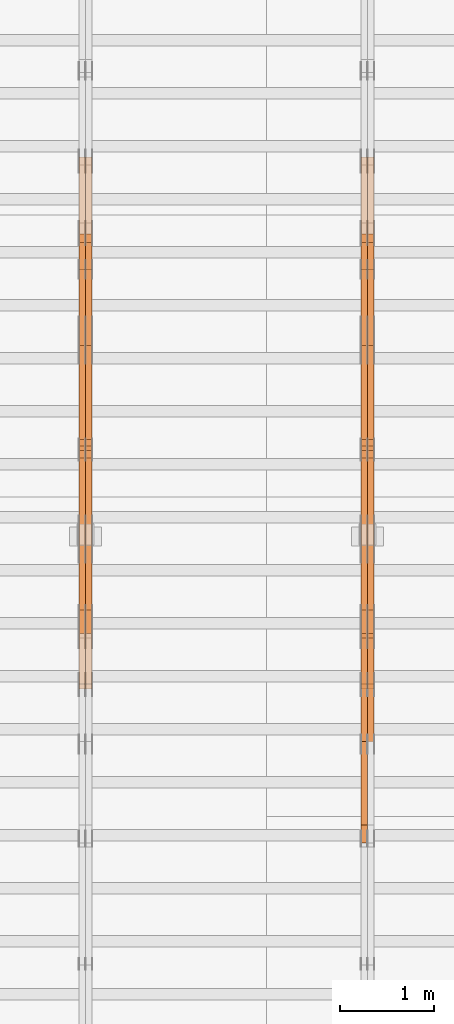
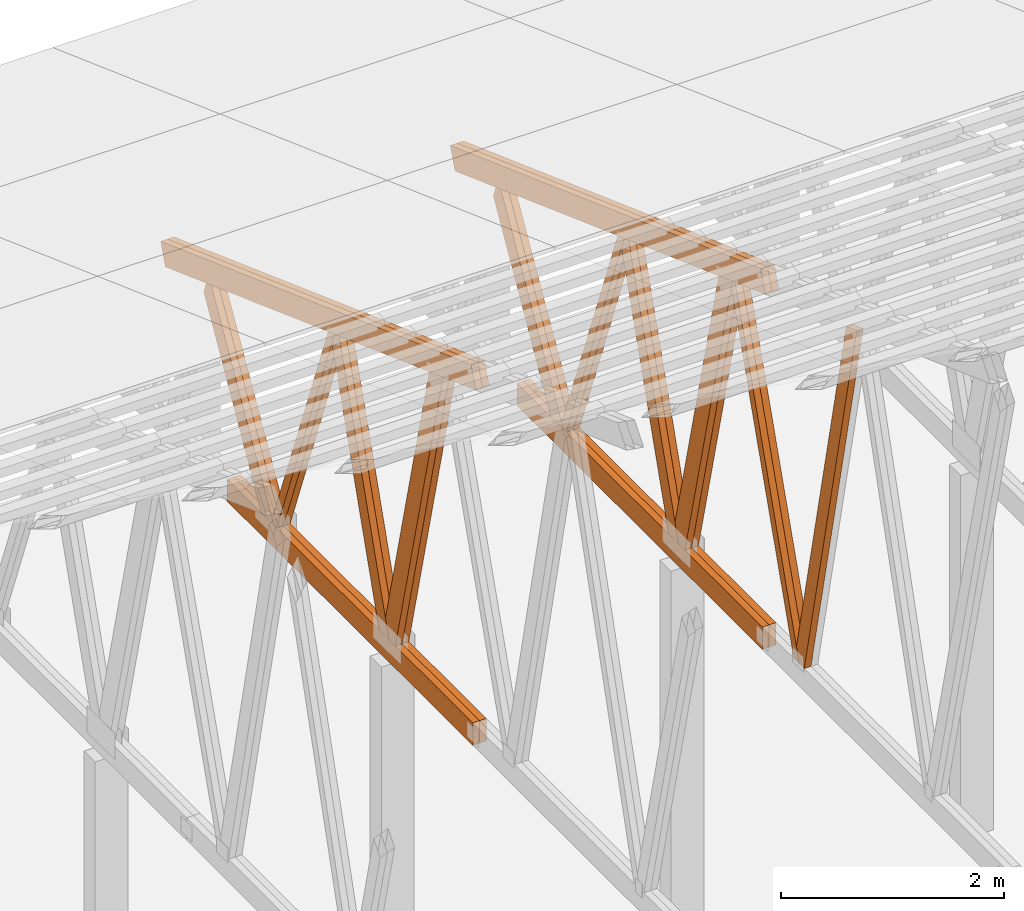
# One storey, part 34 of 189: 27 proxies.
"""IFC2X3 building model written with IfcOpenShell, lengths in millimetres."""

from ifc_helpers import new_model, entity, si_unit, converted_unit, derived_unit, direction, frame, origin, origin_2d_with_axis, place, context, subcontext, project, spatial, polyline, rectangle, outline, extrude, source, transform, mapped, material, type_object, type_shapes, element, save


model = new_model("IFC2X3")

# Units and contexts
model_context = context("Model", 3, precision=0.01, world=origin(), true_north=direction((6.12303176911189e-17, 1.0)))
body_context = subcontext(model_context, "Body", "Model", "MODEL_VIEW")
ifc_project = project(units=[si_unit("LENGTHUNIT", "METRE", prefix="MILLI"), si_unit("AREAUNIT", "SQUARE_METRE"), si_unit("VOLUMEUNIT", "CUBIC_METRE"), converted_unit("PLANEANGLEUNIT", "DEGREE", entity("IfcRatioMeasure", 0.0174532925199433), si_unit("PLANEANGLEUNIT", "RADIAN"), dimensions=[0, 0, 0, 0, 0, 0, 0]), si_unit("MASSUNIT", "GRAM", prefix="KILO"), derived_unit("MASSDENSITYUNIT", [(si_unit("MASSUNIT", "GRAM", prefix="KILO"), 1), (si_unit("LENGTHUNIT", "METRE"), -3)]), si_unit("TIMEUNIT", "SECOND"), si_unit("FREQUENCYUNIT", "HERTZ"), si_unit("THERMODYNAMICTEMPERATUREUNIT", "DEGREE_CELSIUS"), derived_unit("THERMALTRANSMITTANCEUNIT", [(si_unit("MASSUNIT", "GRAM", prefix="KILO"), 1), (si_unit("THERMODYNAMICTEMPERATUREUNIT", "KELVIN"), -1), (si_unit("TIMEUNIT", "SECOND"), -3)]), derived_unit("VOLUMETRICFLOWRATEUNIT", [(si_unit("LENGTHUNIT", "METRE"), 3), (si_unit("TIMEUNIT", "SECOND"), -1)]), si_unit("ELECTRICCURRENTUNIT", "AMPERE"), si_unit("ELECTRICVOLTAGEUNIT", "VOLT"), si_unit("POWERUNIT", "WATT"), si_unit("FORCEUNIT", "NEWTON"), si_unit("ILLUMINANCEUNIT", "LUX"), si_unit("LUMINOUSFLUXUNIT", "LUMEN"), si_unit("LUMINOUSINTENSITYUNIT", "CANDELA"), derived_unit("USERDEFINED", [(si_unit("MASSUNIT", "GRAM", prefix="KILO"), -1), (si_unit("LENGTHUNIT", "METRE"), -2), (si_unit("TIMEUNIT", "SECOND"), 3), (si_unit("LUMINOUSFLUXUNIT", "LUMEN"), 1)]), derived_unit("LINEARVELOCITYUNIT", [(si_unit("LENGTHUNIT", "METRE"), 1), (si_unit("TIMEUNIT", "SECOND"), -1)]), si_unit("PRESSUREUNIT", "PASCAL"), derived_unit("USERDEFINED", [(si_unit("LENGTHUNIT", "METRE"), -2), (si_unit("MASSUNIT", "GRAM", prefix="KILO"), 1), (si_unit("TIMEUNIT", "SECOND"), -2)])], contexts=[model_context])

# Site, building, storey
site_placement = place(None, origin())
site = spatial("IfcSite", under=ifc_project, at=site_placement, CompositionType="ELEMENT")
building_placement = place(site_placement, origin())
building = spatial("IfcBuilding", under=site, at=building_placement, CompositionType="ELEMENT")
storey_placement = place(building_placement, origin())
storey = spatial("IfcBuildingStorey", under=building, at=storey_placement, Name="Default", CompositionType="ELEMENT", Elevation=0.0)

# Proxies
ifc_material_1 = material(Name="IfcSurfaceStyle #67908")
building_element_proxy_type_1 = type_object("IfcBuildingElementProxyType", Name="T1-W3 67906", PredefinedType="NOTDEFINED", material=ifc_material_1)
shared_shape_1 = source(origin(), body_context, "Body", "SweptSolid", [
    extrude(outline(polyline([(-2517.58938959787, -85.0001104675026), (1625.445846867, -85.0001104675027), (1768.20563426494, 0.000209440697654673), (1749.48871563991, 85.0000057471538), (-2625.55080717397, 85.0000057471538), (-2517.58938959787, -85.0001104675026)])), frame((1768.2056683344, 85.0000547211315, 0.0), z_axis=(0.0, 0.0, 1.0), x_axis=(-1.0, 0.0, 0.0)), (0.0, 0.0, 1.0), 69.9999999999997),
])
type_shapes(building_element_proxy_type_1, [shared_shape_1])
proxy_1_placement = place(building_placement, frame((12230.0, 18415.3042863408, 226.720947016584), z_axis=(-1.0, 0.0, 0.0), x_axis=(0.0, -0.215047682154604, 0.976603550269982)))
element("IfcBuildingElementProxy", 1, at=proxy_1_placement, inside=storey, type_object=building_element_proxy_type_1, material=ifc_material_1, Name="T1-W3", context=body_context, shape_type="MappedRepresentation", body=[
    mapped(shared_shape_1, transform((0.0, 0.0, 0.0), scale=1.0)),
])
ifc_material_2 = material(Name="IfcSurfaceStyle #67710")
building_element_proxy_type_2 = type_object("IfcBuildingElementProxyType", Name="T1-W7 67708", PredefinedType="NOTDEFINED", material=ifc_material_2)
shared_shape_2 = source(origin(), body_context, "Body", "SweptSolid", [
    extrude(outline(polyline([(-2189.6662270939, -47.5000140805343), (1475.30081553583, -47.5000140805343), (1473.93388518462, 0.00042343352179337), (1398.58463533215, 47.4998023637734), (-2158.15310895869, 47.4998023637734), (-2189.6662270939, -47.5000140805343)])), frame((1475.30081553583, 47.5004895824757, 0.0), z_axis=(0.0, 0.0, 1.0), x_axis=(-1.0, 0.0, 0.0)), (0.0, 0.0, 1.0), 69.9999999999998),
])
type_shapes(building_element_proxy_type_2, [shared_shape_2])
proxy_2_placement = place(building_placement, frame((12300.0, 19742.3819153401, 3693.66743808885), z_axis=(-1.0, 0.0, 0.0), x_axis=(0.0, -0.314845237923104, -0.949143021971475)))
element("IfcBuildingElementProxy", 2, at=proxy_2_placement, inside=storey, type_object=building_element_proxy_type_2, material=ifc_material_2, Name="T1-W7", context=body_context, shape_type="MappedRepresentation", body=[
    mapped(shared_shape_2, transform((0.0, 0.0, 0.0), scale=1.0)),
])
ifc_material_3 = material(Name="IfcSurfaceStyle #67644")
building_element_proxy_type_3 = type_object("IfcBuildingElementProxyType", Name="T1-W7 67642", PredefinedType="NOTDEFINED", material=ifc_material_3)
shared_shape_3 = source(origin(), body_context, "Body", "SweptSolid", [
    extrude(outline(polyline([(-2189.6662270939, -47.5000140805343), (1475.30081553583, -47.5000140805343), (1473.93388518462, 0.00042343352179337), (1398.58463533215, 47.4998023637734), (-2158.15310895869, 47.4998023637734), (-2189.6662270939, -47.5000140805343)])), frame((1475.30081553583, 47.5004895824757, 0.0), z_axis=(0.0, 0.0, 1.0), x_axis=(-1.0, 0.0, 0.0)), (0.0, 0.0, 1.0), 69.9999999999998),
])
type_shapes(building_element_proxy_type_3, [shared_shape_3])
proxy_3_placement = place(building_placement, frame((12230.0, 19742.3819153401, 3693.66743808885), z_axis=(-1.0, 0.0, 0.0), x_axis=(0.0, -0.314845237923104, -0.949143021971475)))
element("IfcBuildingElementProxy", 3, at=proxy_3_placement, inside=storey, type_object=building_element_proxy_type_3, material=ifc_material_3, Name="T1-W7", context=body_context, shape_type="MappedRepresentation", body=[
    mapped(shared_shape_3, transform((0.0, 0.0, 0.0), scale=1.0)),
])
ifc_material_4 = material(Name="IfcSurfaceStyle #67446")
building_element_proxy_type_4 = type_object("IfcBuildingElementProxyType", Name="T1-W1 67444", PredefinedType="NOTDEFINED", material=ifc_material_4)
shared_shape_4 = source(origin(), body_context, "Body", "SweptSolid", [
    extrude(outline(polyline([(-1996.99427801396, -109.999889649051), (1271.09905152223, -109.999889649051), (1448.88120817726, -0.000113190727324008), (1421.70802776002, 109.999946244415), (-2144.69400944554, 109.999946244415), (-1996.99427801396, -109.999889649051)])), frame((1448.88120817726, 110.000265670598, 0.0), z_axis=(0.0, 0.0, 1.0), x_axis=(-1.0, 0.0, 0.0)), (0.0, 0.0, 1.0), 69.9999999999998),
])
type_shapes(building_element_proxy_type_4, [shared_shape_4])
proxy_4_placement = place(building_placement, frame((12300.0, 20558.6774904859, 218.61972674968), z_axis=(-1.0, 0.0, 0.0), x_axis=(0.0, -0.239819839925979, 0.970817410421691)))
element("IfcBuildingElementProxy", 4, at=proxy_4_placement, inside=storey, type_object=building_element_proxy_type_4, material=ifc_material_4, Name="T1-W1", context=body_context, shape_type="MappedRepresentation", body=[
    mapped(shared_shape_4, transform((0.0, 0.0, 0.0), scale=1.0)),
])
ifc_material_5 = material(Name="IfcSurfaceStyle #67380")
building_element_proxy_type_5 = type_object("IfcBuildingElementProxyType", Name="T1-W1 67378", PredefinedType="NOTDEFINED", material=ifc_material_5)
shared_shape_5 = source(origin(), body_context, "Body", "SweptSolid", [
    extrude(outline(polyline([(-1996.99427801396, -109.999889649051), (1271.09905152223, -109.999889649051), (1448.88120817726, -0.000113190727324008), (1421.70802776002, 109.999946244415), (-2144.69400944554, 109.999946244415), (-1996.99427801396, -109.999889649051)])), frame((1448.88120817726, 110.000265670598, 0.0), z_axis=(0.0, 0.0, 1.0), x_axis=(-1.0, 0.0, 0.0)), (0.0, 0.0, 1.0), 69.9999999999998),
])
type_shapes(building_element_proxy_type_5, [shared_shape_5])
proxy_5_placement = place(building_placement, frame((12230.0, 20558.6774904859, 218.61972674968), z_axis=(-1.0, 0.0, 0.0), x_axis=(0.0, -0.239819839925979, 0.970817410421691)))
element("IfcBuildingElementProxy", 5, at=proxy_5_placement, inside=storey, type_object=building_element_proxy_type_5, material=ifc_material_5, Name="T1-W1", context=body_context, shape_type="MappedRepresentation", body=[
    mapped(shared_shape_5, transform((0.0, 0.0, 0.0), scale=1.0)),
])
ifc_material_6 = material(Name="IfcSurfaceStyle #67182")
building_element_proxy_type_6 = type_object("IfcBuildingElementProxyType", Name="T1-W4 67180", PredefinedType="NOTDEFINED", material=ifc_material_6)
shared_shape_6 = source(origin(), body_context, "Body", "SweptSolid", [
    extrude(outline(polyline([(-1742.90513395849, -84.9997422414737), (1181.3544167489, -84.9997422414737), (1178.19398821251, -0.000208932978430543), (1071.44989130457, 84.999846707963), (-1688.09316230749, 84.999846707963), (-1742.90513395849, -84.9997422414737)])), frame((1181.35452116422, 84.999886337523, 0.0), z_axis=(0.0, 0.0, 1.0), x_axis=(-1.0, 0.0, 0.0)), (0.0, 0.0, 1.0), 69.9999999999998),
])
type_shapes(building_element_proxy_type_6, [shared_shape_6])
proxy_6_placement = place(building_placement, frame((12300.0, 21724.6281517871, 2976.00232464744), z_axis=(-1.0, 0.0, 0.0), x_axis=(0.0, -0.306868406216495, -0.951751953644514)))
element("IfcBuildingElementProxy", 6, at=proxy_6_placement, inside=storey, type_object=building_element_proxy_type_6, material=ifc_material_6, Name="T1-W4", context=body_context, shape_type="MappedRepresentation", body=[
    mapped(shared_shape_6, transform((0.0, 0.0, 0.0), scale=1.0)),
])
ifc_material_7 = material(Name="IfcSurfaceStyle #67116")
building_element_proxy_type_7 = type_object("IfcBuildingElementProxyType", Name="T1-W4 67114", PredefinedType="NOTDEFINED", material=ifc_material_7)
shared_shape_7 = source(origin(), body_context, "Body", "SweptSolid", [
    extrude(outline(polyline([(-1742.90513395849, -84.9997422414737), (1181.3544167489, -84.9997422414737), (1178.19398821251, -0.000208932978430543), (1071.44989130457, 84.999846707963), (-1688.09316230749, 84.999846707963), (-1742.90513395849, -84.9997422414737)])), frame((1181.35452116422, 84.999886337523, 0.0), z_axis=(0.0, 0.0, 1.0), x_axis=(-1.0, 0.0, 0.0)), (0.0, 0.0, 1.0), 69.9999999999998),
])
type_shapes(building_element_proxy_type_7, [shared_shape_7])
proxy_7_placement = place(building_placement, frame((12230.0, 21724.6281517871, 2976.00232464744), z_axis=(-1.0, 0.0, 0.0), x_axis=(0.0, -0.306868406216495, -0.951751953644514)))
element("IfcBuildingElementProxy", 7, at=proxy_7_placement, inside=storey, type_object=building_element_proxy_type_7, material=ifc_material_7, Name="T1-W4", context=body_context, shape_type="MappedRepresentation", body=[
    mapped(shared_shape_7, transform((0.0, 0.0, 0.0), scale=1.0)),
])
ifc_material_8 = material(Name="IfcSurfaceStyle #66918")
building_element_proxy_type_8 = type_object("IfcBuildingElementProxyType", Name="T1-W8 66916", PredefinedType="NOTDEFINED", material=ifc_material_8)
shared_shape_8 = source(origin(), body_context, "Body", "SweptSolid", [
    extrude(outline(polyline([(-1700.10906247918, -47.4998559987011), (1140.60243146647, -47.4998559987011), (1179.56122089033, 0.000120838919977206), (1161.65086478184, 47.4997955792411), (-1781.70545465947, 47.4997955792411), (-1700.10906247918, -47.4998559987011)])), frame((1179.56128464708, 47.5000634692093, 0.0), z_axis=(0.0, 0.0, 1.0), x_axis=(-1.0, 0.0, 0.0)), (0.0, 0.0, 1.0), 69.9999999999998),
])
type_shapes(building_element_proxy_type_8, [shared_shape_8])
proxy_8_placement = place(building_placement, frame((12300.0, 22687.5385403115, 228.241249073207), z_axis=(-1.0, 0.0, 0.0), x_axis=(0.0, -0.352814979177604, 0.93569310698963)))
element("IfcBuildingElementProxy", 8, at=proxy_8_placement, inside=storey, type_object=building_element_proxy_type_8, material=ifc_material_8, Name="T1-W8", context=body_context, shape_type="MappedRepresentation", body=[
    mapped(shared_shape_8, transform((0.0, 0.0, 0.0), scale=1.0)),
])
ifc_material_9 = material(Name="IfcSurfaceStyle #66852")
building_element_proxy_type_9 = type_object("IfcBuildingElementProxyType", Name="T1-W8 66850", PredefinedType="NOTDEFINED", material=ifc_material_9)
shared_shape_9 = source(origin(), body_context, "Body", "SweptSolid", [
    extrude(outline(polyline([(-1700.10906247918, -47.4998559987011), (1140.60243146647, -47.4998559987011), (1179.56122089033, 0.000120838919977206), (1161.65086478184, 47.4997955792411), (-1781.70545465947, 47.4997955792411), (-1700.10906247918, -47.4998559987011)])), frame((1179.56128464708, 47.5000634692093, 0.0), z_axis=(0.0, 0.0, 1.0), x_axis=(-1.0, 0.0, 0.0)), (0.0, 0.0, 1.0), 69.9999999999998),
])
type_shapes(building_element_proxy_type_9, [shared_shape_9])
proxy_9_placement = place(building_placement, frame((12230.0, 22687.5385403115, 228.241249073207), z_axis=(-1.0, 0.0, 0.0), x_axis=(0.0, -0.352814979177604, 0.93569310698963)))
element("IfcBuildingElementProxy", 9, at=proxy_9_placement, inside=storey, type_object=building_element_proxy_type_9, material=ifc_material_9, Name="T1-W8", context=body_context, shape_type="MappedRepresentation", body=[
    mapped(shared_shape_9, transform((0.0, 0.0, 0.0), scale=1.0)),
])
ifc_material_10 = material(Name="IfcSurfaceStyle #66654")
building_element_proxy_type_10 = type_object("IfcBuildingElementProxyType", Name="T1-W2 66652", PredefinedType="NOTDEFINED", material=ifc_material_10)
shared_shape_10 = source(origin(), body_context, "Body", "SweptSolid", [
    extrude(outline(polyline([(-1361.89144606429, -97.5000598486876), (887.613245225805, -97.5000598486876), (904.774262962339, 0.000302345139042259), (818.892339969004, 97.4999086761182), (-1249.38840209286, 97.4999086761182), (-1361.89144606429, -97.5000598486876)])), frame((904.774262962339, 97.5000966763391, 0.0), z_axis=(0.0, 0.0, 1.0), x_axis=(-1.0, 0.0, 0.0)), (0.0, 0.0, 1.0), 69.9999999999999),
])
type_shapes(building_element_proxy_type_10, [shared_shape_10])
proxy_10_placement = place(building_placement, frame((12300.0, 24033.6159173732, 2110.89189244614), z_axis=(-1.0, 0.0, 0.0), x_axis=(0.0, -0.5, -0.866025403784439)))
element("IfcBuildingElementProxy", 10, at=proxy_10_placement, inside=storey, type_object=building_element_proxy_type_10, material=ifc_material_10, Name="T1-W2", context=body_context, shape_type="MappedRepresentation", body=[
    mapped(shared_shape_10, transform((0.0, 0.0, 0.0), scale=1.0)),
])
ifc_material_11 = material(Name="IfcSurfaceStyle #66588")
building_element_proxy_type_11 = type_object("IfcBuildingElementProxyType", Name="T1-W2 66586", PredefinedType="NOTDEFINED", material=ifc_material_11)
shared_shape_11 = source(origin(), body_context, "Body", "SweptSolid", [
    extrude(outline(polyline([(-1361.89144606429, -97.5000598486876), (887.613245225805, -97.5000598486876), (904.774262962339, 0.000302345139042259), (818.892339969004, 97.4999086761182), (-1249.38840209286, 97.4999086761182), (-1361.89144606429, -97.5000598486876)])), frame((904.774262962339, 97.5000966763391, 0.0), z_axis=(0.0, 0.0, 1.0), x_axis=(-1.0, 0.0, 0.0)), (0.0, 0.0, 1.0), 69.9999999999999),
])
type_shapes(building_element_proxy_type_11, [shared_shape_11])
proxy_11_placement = place(building_placement, frame((12230.0, 24033.6159173732, 2110.89189244614), z_axis=(-1.0, 0.0, 0.0), x_axis=(0.0, -0.5, -0.866025403784439)))
element("IfcBuildingElementProxy", 11, at=proxy_11_placement, inside=storey, type_object=building_element_proxy_type_11, material=ifc_material_11, Name="T1-W2", context=body_context, shape_type="MappedRepresentation", body=[
    mapped(shared_shape_11, transform((0.0, 0.0, 0.0), scale=1.0)),
])
ifc_material_12 = material(Name="IfcSurfaceStyle #64578")
building_element_proxy_type_12 = type_object("IfcBuildingElementProxyType", Name="T1-B4 64576", PredefinedType="NOTDEFINED", material=ifc_material_12)
shared_shape_12 = source(origin(), body_context, "Body", "SweptSolid", [
    extrude(rectangle(XDim=4408.2412109375, YDim=245.000000000001, at=origin_2d_with_axis()), frame((2204.12060546875, 122.5, 0.0), z_axis=(0.0, 0.0, 1.0), x_axis=(-1.0, 0.0, 0.0)), (0.0, 0.0, 1.0), 69.9999999999997),
])
type_shapes(building_element_proxy_type_12, [shared_shape_12])
proxy_12_placement = place(building_placement, frame((12300.0, 19161.7587890625, 245.0), z_axis=(-1.0, 0.0, 0.0), x_axis=(0.0, 1.0, 0.0)))
element("IfcBuildingElementProxy", 12, at=proxy_12_placement, inside=storey, type_object=building_element_proxy_type_12, material=ifc_material_12, Name="T1-B4", context=body_context, shape_type="MappedRepresentation", body=[
    mapped(shared_shape_12, transform((0.0, 0.0, 0.0), scale=1.0)),
])
ifc_material_13 = material(Name="IfcSurfaceStyle #64521")
building_element_proxy_type_13 = type_object("IfcBuildingElementProxyType", Name="T1-B4 64519", PredefinedType="NOTDEFINED", material=ifc_material_13)
shared_shape_13 = source(origin(), body_context, "Body", "SweptSolid", [
    extrude(rectangle(XDim=4408.2412109375, YDim=245.000000000001, at=origin_2d_with_axis()), frame((2204.12060546875, 122.5, 0.0), z_axis=(0.0, 0.0, 1.0), x_axis=(-1.0, 0.0, 0.0)), (0.0, 0.0, 1.0), 69.9999999999997),
])
type_shapes(building_element_proxy_type_13, [shared_shape_13])
proxy_13_placement = place(building_placement, frame((12230.0, 19161.7587890625, 245.0), z_axis=(-1.0, 0.0, 0.0), x_axis=(0.0, 1.0, 0.0)))
element("IfcBuildingElementProxy", 13, at=proxy_13_placement, inside=storey, type_object=building_element_proxy_type_13, material=ifc_material_13, Name="T1-B4", context=body_context, shape_type="MappedRepresentation", body=[
    mapped(shared_shape_13, transform((0.0, 0.0, 0.0), scale=1.0)),
])
ifc_material_14 = material(Name="IfcSurfaceStyle #63534")
building_element_proxy_type_14 = type_object("IfcBuildingElementProxyType", Name="T1-T1 63532", PredefinedType="NOTDEFINED", material=ifc_material_14)
shared_shape_14 = source(origin(), body_context, "Body", "SweptSolid", [
    extrude(outline(polyline([(-2964.99982426074, -122.499947708046), (2964.99981923522, -122.499947708046), (2964.99984513599, 122.499947708046), (-2964.99984011047, 122.499947708046), (-2964.99982426074, -122.499947708046)])), frame((2964.99984513599, 122.499998966405, 0.0), z_axis=(0.0, 0.0, 1.0), x_axis=(-1.0, 0.0, 0.0)), (0.0, 0.0, 1.0), 69.9999999999996),
])
type_shapes(building_element_proxy_type_14, [shared_shape_14])
proxy_14_placement = place(building_placement, frame((12300.0, 24681.3398262186, 1893.12531804384), z_axis=(-1.0, 0.0, 0.0), x_axis=(0.0, -0.939692620785908, 0.342020143325669)))
element("IfcBuildingElementProxy", 14, at=proxy_14_placement, inside=storey, type_object=building_element_proxy_type_14, material=ifc_material_14, Name="T1-T1", context=body_context, shape_type="MappedRepresentation", body=[
    mapped(shared_shape_14, transform((0.0, 0.0, 0.0), scale=1.0)),
])
ifc_material_15 = material(Name="IfcSurfaceStyle #63477")
building_element_proxy_type_15 = type_object("IfcBuildingElementProxyType", Name="T1-T1 63475", PredefinedType="NOTDEFINED", material=ifc_material_15)
shared_shape_15 = source(origin(), body_context, "Body", "SweptSolid", [
    extrude(outline(polyline([(-2964.99982426074, -122.499947708046), (2964.99981923522, -122.499947708046), (2964.99984513599, 122.499947708046), (-2964.99984011047, 122.499947708046), (-2964.99982426074, -122.499947708046)])), frame((2964.99984513599, 122.499998966405, 0.0), z_axis=(0.0, 0.0, 1.0), x_axis=(-1.0, 0.0, 0.0)), (0.0, 0.0, 1.0), 69.9999999999996),
])
type_shapes(building_element_proxy_type_15, [shared_shape_15])
proxy_15_placement = place(building_placement, frame((12230.0, 24681.3398262186, 1893.12531804384), z_axis=(-1.0, 0.0, 0.0), x_axis=(0.0, -0.939692620785908, 0.342020143325669)))
element("IfcBuildingElementProxy", 15, at=proxy_15_placement, inside=storey, type_object=building_element_proxy_type_15, material=ifc_material_15, Name="T1-T1", context=body_context, shape_type="MappedRepresentation", body=[
    mapped(shared_shape_15, transform((0.0, 0.0, 0.0), scale=1.0)),
])
ifc_material_16 = material(Name="IfcSurfaceStyle #51656")
building_element_proxy_type_16 = type_object("IfcBuildingElementProxyType", Name="T1-W1 51654", PredefinedType="NOTDEFINED", material=ifc_material_16)
shared_shape_16 = source(origin(), body_context, "Body", "SweptSolid", [
    extrude(outline(polyline([(-1996.99427801396, -109.999889649051), (1271.09905152223, -109.999889649051), (1448.88120817726, -0.000113190727324008), (1421.70802776002, 109.999946244415), (-2144.69400944554, 109.999946244415), (-1996.99427801396, -109.999889649051)])), frame((1448.88120817726, 110.000265670598, 0.0), z_axis=(0.0, 0.0, 1.0), x_axis=(-1.0, 0.0, 0.0)), (0.0, 0.0, 1.0), 69.9999999999998),
])
type_shapes(building_element_proxy_type_16, [shared_shape_16])
proxy_16_placement = place(building_placement, frame((9300.0, 20558.6774904859, 218.61972674968), z_axis=(-1.0, 0.0, 0.0), x_axis=(0.0, -0.239819839925979, 0.970817410421691)))
element("IfcBuildingElementProxy", 16, at=proxy_16_placement, inside=storey, type_object=building_element_proxy_type_16, material=ifc_material_16, Name="T1-W1", context=body_context, shape_type="MappedRepresentation", body=[
    mapped(shared_shape_16, transform((0.0, 0.0, 0.0), scale=1.0)),
])
ifc_material_17 = material(Name="IfcSurfaceStyle #51590")
building_element_proxy_type_17 = type_object("IfcBuildingElementProxyType", Name="T1-W1 51588", PredefinedType="NOTDEFINED", material=ifc_material_17)
shared_shape_17 = source(origin(), body_context, "Body", "SweptSolid", [
    extrude(outline(polyline([(-1996.99427801396, -109.999889649051), (1271.09905152223, -109.999889649051), (1448.88120817726, -0.000113190727324008), (1421.70802776002, 109.999946244415), (-2144.69400944554, 109.999946244415), (-1996.99427801396, -109.999889649051)])), frame((1448.88120817726, 110.000265670598, 0.0), z_axis=(0.0, 0.0, 1.0), x_axis=(-1.0, 0.0, 0.0)), (0.0, 0.0, 1.0), 69.9999999999998),
])
type_shapes(building_element_proxy_type_17, [shared_shape_17])
proxy_17_placement = place(building_placement, frame((9230.0, 20558.6774904859, 218.61972674968), z_axis=(-1.0, 0.0, 0.0), x_axis=(0.0, -0.239819839925979, 0.970817410421691)))
element("IfcBuildingElementProxy", 17, at=proxy_17_placement, inside=storey, type_object=building_element_proxy_type_17, material=ifc_material_17, Name="T1-W1", context=body_context, shape_type="MappedRepresentation", body=[
    mapped(shared_shape_17, transform((0.0, 0.0, 0.0), scale=1.0)),
])
ifc_material_18 = material(Name="IfcSurfaceStyle #51392")
building_element_proxy_type_18 = type_object("IfcBuildingElementProxyType", Name="T1-W4 51390", PredefinedType="NOTDEFINED", material=ifc_material_18)
shared_shape_18 = source(origin(), body_context, "Body", "SweptSolid", [
    extrude(outline(polyline([(-1742.90513395849, -84.9997422414737), (1181.3544167489, -84.9997422414737), (1178.19398821251, -0.000208932978430543), (1071.44989130457, 84.999846707963), (-1688.09316230749, 84.999846707963), (-1742.90513395849, -84.9997422414737)])), frame((1181.35452116422, 84.999886337523, 0.0), z_axis=(0.0, 0.0, 1.0), x_axis=(-1.0, 0.0, 0.0)), (0.0, 0.0, 1.0), 69.9999999999998),
])
type_shapes(building_element_proxy_type_18, [shared_shape_18])
proxy_18_placement = place(building_placement, frame((9300.0, 21724.6281517871, 2976.00232464744), z_axis=(-1.0, 0.0, 0.0), x_axis=(0.0, -0.306868406216495, -0.951751953644514)))
element("IfcBuildingElementProxy", 18, at=proxy_18_placement, inside=storey, type_object=building_element_proxy_type_18, material=ifc_material_18, Name="T1-W4", context=body_context, shape_type="MappedRepresentation", body=[
    mapped(shared_shape_18, transform((0.0, 0.0, 0.0), scale=1.0)),
])
ifc_material_19 = material(Name="IfcSurfaceStyle #51326")
building_element_proxy_type_19 = type_object("IfcBuildingElementProxyType", Name="T1-W4 51324", PredefinedType="NOTDEFINED", material=ifc_material_19)
shared_shape_19 = source(origin(), body_context, "Body", "SweptSolid", [
    extrude(outline(polyline([(-1742.90513395849, -84.9997422414737), (1181.3544167489, -84.9997422414737), (1178.19398821251, -0.000208932978430543), (1071.44989130457, 84.999846707963), (-1688.09316230749, 84.999846707963), (-1742.90513395849, -84.9997422414737)])), frame((1181.35452116422, 84.999886337523, 0.0), z_axis=(0.0, 0.0, 1.0), x_axis=(-1.0, 0.0, 0.0)), (0.0, 0.0, 1.0), 69.9999999999998),
])
type_shapes(building_element_proxy_type_19, [shared_shape_19])
proxy_19_placement = place(building_placement, frame((9230.0, 21724.6281517871, 2976.00232464744), z_axis=(-1.0, 0.0, 0.0), x_axis=(0.0, -0.306868406216495, -0.951751953644514)))
element("IfcBuildingElementProxy", 19, at=proxy_19_placement, inside=storey, type_object=building_element_proxy_type_19, material=ifc_material_19, Name="T1-W4", context=body_context, shape_type="MappedRepresentation", body=[
    mapped(shared_shape_19, transform((0.0, 0.0, 0.0), scale=1.0)),
])
ifc_material_20 = material(Name="IfcSurfaceStyle #51128")
building_element_proxy_type_20 = type_object("IfcBuildingElementProxyType", Name="T1-W8 51126", PredefinedType="NOTDEFINED", material=ifc_material_20)
shared_shape_20 = source(origin(), body_context, "Body", "SweptSolid", [
    extrude(outline(polyline([(-1700.10906247918, -47.4998559987011), (1140.60243146647, -47.4998559987011), (1179.56122089033, 0.000120838919977206), (1161.65086478184, 47.4997955792411), (-1781.70545465947, 47.4997955792411), (-1700.10906247918, -47.4998559987011)])), frame((1179.56128464708, 47.5000634692093, 0.0), z_axis=(0.0, 0.0, 1.0), x_axis=(-1.0, 0.0, 0.0)), (0.0, 0.0, 1.0), 69.9999999999998),
])
type_shapes(building_element_proxy_type_20, [shared_shape_20])
proxy_20_placement = place(building_placement, frame((9300.0, 22687.5385403115, 228.241249073207), z_axis=(-1.0, 0.0, 0.0), x_axis=(0.0, -0.352814979177604, 0.93569310698963)))
element("IfcBuildingElementProxy", 20, at=proxy_20_placement, inside=storey, type_object=building_element_proxy_type_20, material=ifc_material_20, Name="T1-W8", context=body_context, shape_type="MappedRepresentation", body=[
    mapped(shared_shape_20, transform((0.0, 0.0, 0.0), scale=1.0)),
])
ifc_material_21 = material(Name="IfcSurfaceStyle #51062")
building_element_proxy_type_21 = type_object("IfcBuildingElementProxyType", Name="T1-W8 51060", PredefinedType="NOTDEFINED", material=ifc_material_21)
shared_shape_21 = source(origin(), body_context, "Body", "SweptSolid", [
    extrude(outline(polyline([(-1700.10906247918, -47.4998559987011), (1140.60243146647, -47.4998559987011), (1179.56122089033, 0.000120838919977206), (1161.65086478184, 47.4997955792411), (-1781.70545465947, 47.4997955792411), (-1700.10906247918, -47.4998559987011)])), frame((1179.56128464708, 47.5000634692093, 0.0), z_axis=(0.0, 0.0, 1.0), x_axis=(-1.0, 0.0, 0.0)), (0.0, 0.0, 1.0), 69.9999999999998),
])
type_shapes(building_element_proxy_type_21, [shared_shape_21])
proxy_21_placement = place(building_placement, frame((9230.0, 22687.5385403115, 228.241249073207), z_axis=(-1.0, 0.0, 0.0), x_axis=(0.0, -0.352814979177604, 0.93569310698963)))
element("IfcBuildingElementProxy", 21, at=proxy_21_placement, inside=storey, type_object=building_element_proxy_type_21, material=ifc_material_21, Name="T1-W8", context=body_context, shape_type="MappedRepresentation", body=[
    mapped(shared_shape_21, transform((0.0, 0.0, 0.0), scale=1.0)),
])
ifc_material_22 = material(Name="IfcSurfaceStyle #50864")
building_element_proxy_type_22 = type_object("IfcBuildingElementProxyType", Name="T1-W2 50862", PredefinedType="NOTDEFINED", material=ifc_material_22)
shared_shape_22 = source(origin(), body_context, "Body", "SweptSolid", [
    extrude(outline(polyline([(-1361.89144606429, -97.5000598486876), (887.613245225805, -97.5000598486876), (904.774262962339, 0.000302345139042259), (818.892339969004, 97.4999086761182), (-1249.38840209286, 97.4999086761182), (-1361.89144606429, -97.5000598486876)])), frame((904.774262962339, 97.5000966763391, 0.0), z_axis=(0.0, 0.0, 1.0), x_axis=(-1.0, 0.0, 0.0)), (0.0, 0.0, 1.0), 69.9999999999999),
])
type_shapes(building_element_proxy_type_22, [shared_shape_22])
proxy_22_placement = place(building_placement, frame((9300.0, 24033.6159173732, 2110.89189244614), z_axis=(-1.0, 0.0, 0.0), x_axis=(0.0, -0.5, -0.866025403784439)))
element("IfcBuildingElementProxy", 22, at=proxy_22_placement, inside=storey, type_object=building_element_proxy_type_22, material=ifc_material_22, Name="T1-W2", context=body_context, shape_type="MappedRepresentation", body=[
    mapped(shared_shape_22, transform((0.0, 0.0, 0.0), scale=1.0)),
])
ifc_material_23 = material(Name="IfcSurfaceStyle #50798")
building_element_proxy_type_23 = type_object("IfcBuildingElementProxyType", Name="T1-W2 50796", PredefinedType="NOTDEFINED", material=ifc_material_23)
shared_shape_23 = source(origin(), body_context, "Body", "SweptSolid", [
    extrude(outline(polyline([(-1361.89144606429, -97.5000598486876), (887.613245225805, -97.5000598486876), (904.774262962339, 0.000302345139042259), (818.892339969004, 97.4999086761182), (-1249.38840209286, 97.4999086761182), (-1361.89144606429, -97.5000598486876)])), frame((904.774262962339, 97.5000966763391, 0.0), z_axis=(0.0, 0.0, 1.0), x_axis=(-1.0, 0.0, 0.0)), (0.0, 0.0, 1.0), 69.9999999999999),
])
type_shapes(building_element_proxy_type_23, [shared_shape_23])
proxy_23_placement = place(building_placement, frame((9230.0, 24033.6159173732, 2110.89189244614), z_axis=(-1.0, 0.0, 0.0), x_axis=(0.0, -0.5, -0.866025403784439)))
element("IfcBuildingElementProxy", 23, at=proxy_23_placement, inside=storey, type_object=building_element_proxy_type_23, material=ifc_material_23, Name="T1-W2", context=body_context, shape_type="MappedRepresentation", body=[
    mapped(shared_shape_23, transform((0.0, 0.0, 0.0), scale=1.0)),
])
ifc_material_24 = material(Name="IfcSurfaceStyle #48788")
building_element_proxy_type_24 = type_object("IfcBuildingElementProxyType", Name="T1-B4 48786", PredefinedType="NOTDEFINED", material=ifc_material_24)
shared_shape_24 = source(origin(), body_context, "Body", "SweptSolid", [
    extrude(rectangle(XDim=4408.2412109375, YDim=245.000000000001, at=origin_2d_with_axis()), frame((2204.12060546875, 122.5, 0.0), z_axis=(0.0, 0.0, 1.0), x_axis=(-1.0, 0.0, 0.0)), (0.0, 0.0, 1.0), 69.9999999999997),
])
type_shapes(building_element_proxy_type_24, [shared_shape_24])
proxy_24_placement = place(building_placement, frame((9300.0, 19161.7587890625, 245.0), z_axis=(-1.0, 0.0, 0.0), x_axis=(0.0, 1.0, 0.0)))
element("IfcBuildingElementProxy", 24, at=proxy_24_placement, inside=storey, type_object=building_element_proxy_type_24, material=ifc_material_24, Name="T1-B4", context=body_context, shape_type="MappedRepresentation", body=[
    mapped(shared_shape_24, transform((0.0, 0.0, 0.0), scale=1.0)),
])
ifc_material_25 = material(Name="IfcSurfaceStyle #48731")
building_element_proxy_type_25 = type_object("IfcBuildingElementProxyType", Name="T1-B4 48729", PredefinedType="NOTDEFINED", material=ifc_material_25)
shared_shape_25 = source(origin(), body_context, "Body", "SweptSolid", [
    extrude(rectangle(XDim=4408.2412109375, YDim=245.000000000001, at=origin_2d_with_axis()), frame((2204.12060546875, 122.5, 0.0), z_axis=(0.0, 0.0, 1.0), x_axis=(-1.0, 0.0, 0.0)), (0.0, 0.0, 1.0), 69.9999999999997),
])
type_shapes(building_element_proxy_type_25, [shared_shape_25])
proxy_25_placement = place(building_placement, frame((9230.0, 19161.7587890625, 245.0), z_axis=(-1.0, 0.0, 0.0), x_axis=(0.0, 1.0, 0.0)))
element("IfcBuildingElementProxy", 25, at=proxy_25_placement, inside=storey, type_object=building_element_proxy_type_25, material=ifc_material_25, Name="T1-B4", context=body_context, shape_type="MappedRepresentation", body=[
    mapped(shared_shape_25, transform((0.0, 0.0, 0.0), scale=1.0)),
])
ifc_material_26 = material(Name="IfcSurfaceStyle #47744")
building_element_proxy_type_26 = type_object("IfcBuildingElementProxyType", Name="T1-T1 47742", PredefinedType="NOTDEFINED", material=ifc_material_26)
shared_shape_26 = source(origin(), body_context, "Body", "SweptSolid", [
    extrude(outline(polyline([(-2964.99982426074, -122.499947708046), (2964.99981923522, -122.499947708046), (2964.99984513599, 122.499947708046), (-2964.99984011047, 122.499947708046), (-2964.99982426074, -122.499947708046)])), frame((2964.99984513599, 122.499998966405, 0.0), z_axis=(0.0, 0.0, 1.0), x_axis=(-1.0, 0.0, 0.0)), (0.0, 0.0, 1.0), 69.9999999999996),
])
type_shapes(building_element_proxy_type_26, [shared_shape_26])
proxy_26_placement = place(building_placement, frame((9300.0, 24681.3398262186, 1893.12531804384), z_axis=(-1.0, 0.0, 0.0), x_axis=(0.0, -0.939692620785908, 0.342020143325669)))
element("IfcBuildingElementProxy", 26, at=proxy_26_placement, inside=storey, type_object=building_element_proxy_type_26, material=ifc_material_26, Name="T1-T1", context=body_context, shape_type="MappedRepresentation", body=[
    mapped(shared_shape_26, transform((0.0, 0.0, 0.0), scale=1.0)),
])
ifc_material_27 = material(Name="IfcSurfaceStyle #47687")
building_element_proxy_type_27 = type_object("IfcBuildingElementProxyType", Name="T1-T1 47685", PredefinedType="NOTDEFINED", material=ifc_material_27)
shared_shape_27 = source(origin(), body_context, "Body", "SweptSolid", [
    extrude(outline(polyline([(-2964.99982426074, -122.499947708046), (2964.99981923522, -122.499947708046), (2964.99984513599, 122.499947708046), (-2964.99984011047, 122.499947708046), (-2964.99982426074, -122.499947708046)])), frame((2964.99984513599, 122.499998966405, 0.0), z_axis=(0.0, 0.0, 1.0), x_axis=(-1.0, 0.0, 0.0)), (0.0, 0.0, 1.0), 69.9999999999996),
])
type_shapes(building_element_proxy_type_27, [shared_shape_27])
proxy_27_placement = place(building_placement, frame((9230.0, 24681.3398262186, 1893.12531804384), z_axis=(-1.0, 0.0, 0.0), x_axis=(0.0, -0.939692620785908, 0.342020143325669)))
element("IfcBuildingElementProxy", 27, at=proxy_27_placement, inside=storey, type_object=building_element_proxy_type_27, material=ifc_material_27, Name="T1-T1", context=body_context, shape_type="MappedRepresentation", body=[
    mapped(shared_shape_27, transform((0.0, 0.0, 0.0), scale=1.0)),
])

save(model, "model.ifc")
